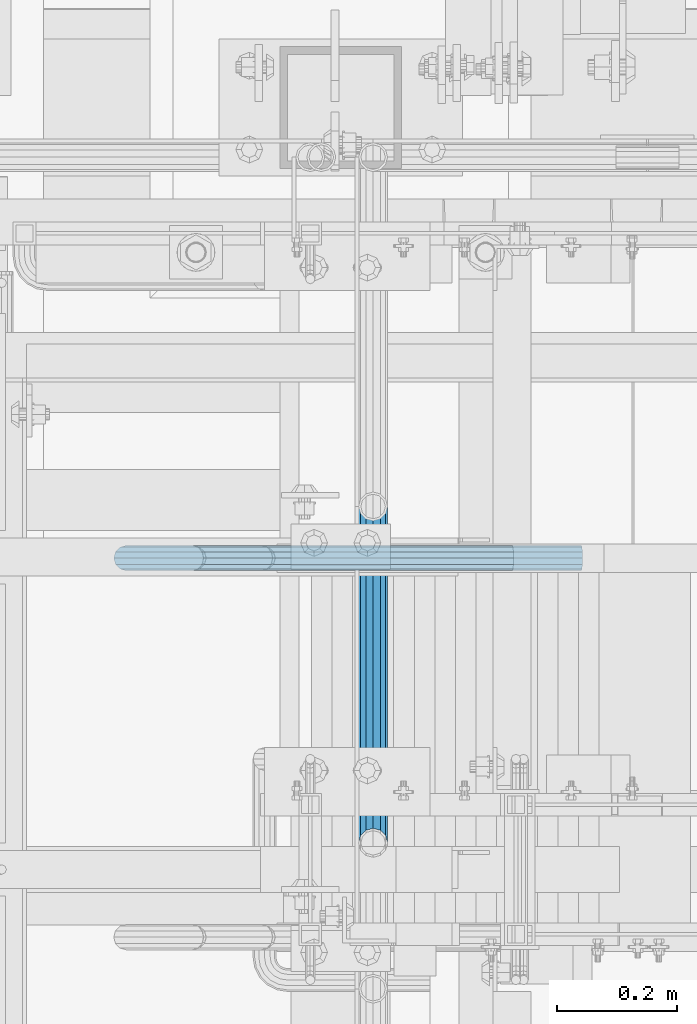
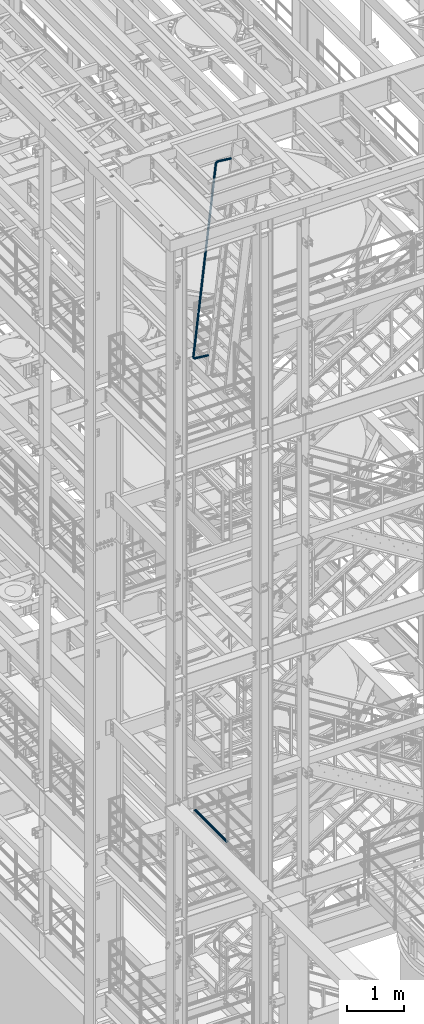
# One storey, part 964 of 1876: 2 beams, 2 elements without a shape of their own.
"""IFC2X3 building model written with IfcOpenShell, lengths in millimetres."""

from ifc_helpers import new_model, si_unit, frame, origin_with_axes, place, context, subcontext, project, spatial, faceted_brep, material, type_object, element, aggregate, save


model = new_model("IFC2X3")

# Units and contexts
model_context = context("Model", 3, precision=1e-05, world=origin_with_axes())
body_context = subcontext(model_context, "Body", "Model", "MODEL_VIEW")
ifc_project = project(units=[si_unit("LENGTHUNIT", "METRE", prefix="MILLI"), si_unit("AREAUNIT", "SQUARE_METRE"), si_unit("VOLUMEUNIT", "CUBIC_METRE"), si_unit("MASSUNIT", "GRAM", prefix="KILO"), si_unit("TIMEUNIT", "SECOND"), si_unit("PLANEANGLEUNIT", "RADIAN"), si_unit("SOLIDANGLEUNIT", "STERADIAN"), si_unit("THERMODYNAMICTEMPERATUREUNIT", "DEGREE_CELSIUS"), si_unit("LUMINOUSINTENSITYUNIT", "LUMEN")], contexts=[model_context])

# Site, building, storey
site_placement = place(None, origin_with_axes())
site = spatial("IfcSite", under=ifc_project, at=site_placement, CompositionType="ELEMENT")
building_placement = place(site_placement, origin_with_axes())
building = spatial("IfcBuilding", under=site, at=building_placement, Name="Undefined", CompositionType="ELEMENT")
storey_placement = place(building_placement, origin_with_axes())
storey = spatial("IfcBuildingStorey", under=building, at=storey_placement, Name="Undefined", CompositionType="ELEMENT", Elevation=0.0)

# Assembly, beam
assembly_1_placement = place(storey_placement, origin_with_axes())
assembly_1 = element("IfcElementAssembly", 1, at=assembly_1_placement, inside=storey, Name="RAIL", AssemblyPlace="NOTDEFINED", PredefinedType="RIGID_FRAME")
ifc_material = material()
beam_type_1 = type_object("IfcBeamType", Name="PIPE1-1/2SCH40", PredefinedType="NOTDEFINED")
beam_1_placement = place(assembly_1_placement, frame((1781.17499999995, -4654.55000114554, 8315.325), z_axis=(0.0, 0.0, 1.0), x_axis=(0.0, -1.0, 0.0)))
beam_1 = element("IfcBeam", 2, at=beam_1_placement, type_object=beam_type_1, material=ifc_material, Name="RAIL", ObjectType="PIPE1-1/2SCH40", context=body_context, shape_type="Brep", body=[
    faceted_brep([(1122.10280643392, -12.0650000000001, 20.8971929933177), (1122.10280643392, -12.0650000010112, 15.8661214301701), (1121.60937799578, -10.2235000000001, 17.7076214311801), (1118.86999942724, -2.11457518162206e-11, 20.4470000000001), (1118.86999942724, -2.11457518162206e-11, 24.1299999999992), (1121.60937799633, 10.2235000000001, 17.7076214311801), (1122.10280643392, 12.0649999989889, 15.866121432191), (1122.10280643392, 12.0650000000001, 20.8971929933177), (1142.99999942723, 24.1300000000001, 0.0), (1130.93499942724, 20.8971929933184, 12.0650000000005), (1130.93499942724, 20.8971929933184, -12.0650000000005), (1127.74542786611, 17.7076214311803, 10.2235000000001), (1130.48480643493, 20.4469999999999, 0.0), (1127.74542786611, 17.7076214311803, -10.2235000000001), (1122.10280643392, 12.0649999989889, -15.866121432191), (1122.10280643392, 12.0650000000001, -20.8971929933177), (1121.60937799633, 10.2235000000001, -17.7076214311801), (1118.86999942724, 0.0, -20.4470000000001), (1118.86999942724, 0.0, -24.1299999999992), (1122.10280643392, -12.0650000010112, -15.8661214301701), (1122.10280643392, -12.0650000000001, -20.8971929933177), (1121.60937799578, -10.2235000000001, -17.7076214311801), (1142.99999942724, -24.1300000010112, 0.0), (1130.93499942724, -20.8971929933184, -12.0650000000005), (1130.93499942724, -20.8971929933184, 12.0650000000005), (1127.74542786409, -17.7076214311803, -10.2235000000001), (1130.48480643291, -20.4469999999999, 0.0), (1127.74542786409, -17.7076214311803, 10.2235000000001), (12.0650000000064, -20.8971929933177, -12.0649999999987), (20.8971929933249, -12.0650000000005, -20.8971929933177), (0.0, 24.1299999999992, 0.0), (12.0650000000064, 20.8971929933177, -12.0649999999987), (12.0650000000064, 20.8971929933177, 12.0649999999987), (20.8971929933249, 12.0650000000005, 20.8971929933177), (24.1300000000064, 0.0, 24.130000000001), (20.8971929933249, 12.0650000000005, -20.8971929933177), (24.1300000000063, 0.0, -24.130000000001), (24.1300000000063, 0.0, -20.4470000000001), (20.8971929933249, -12.0650000000005, -15.8661214311796), (21.3906214311868, -10.2235000000001, -17.7076214311819), (21.3906214311868, 10.2235000000001, -17.7076214311819), (20.8971929933249, 12.0650000000005, -15.8661214311796), (15.2545715621445, 17.7076214311801, -10.2235000000001), (12.5151929933249, 20.4470000000001, 0.0), (15.2545715621445, 17.7076214311801, 10.2235000000001), (20.8971929933249, 12.0650000000005, 15.8661214311796), (21.3906214311868, 10.2235000000001, 17.7076214311819), (24.1300000000064, 0.0, 20.4470000000001), (21.3906214311868, -10.2235000000001, 17.7076214311819), (20.8971929933249, -12.0650000000005, 15.8661214311796), (20.8971929933249, -12.0650000000005, 20.8971929933177), (12.0650000000064, -20.8971929933177, 12.0649999999987), (0.0, -24.1299999999992, 0.0), (15.2545715621445, -17.7076214311801, 10.2235000000001), (12.5151929933249, -20.4470000000001, 0.0), (15.2545715621445, -17.7076214311801, -10.2235000000001)], [[[0, 1, 2, 3, 4]], [[4, 3, 5, 6, 7]], [[8, 9, 10]], [[7, 6, 11, 12, 13, 14, 15, 10, 9]], [[16, 17, 18, 15, 14]], [[19, 20, 18, 17, 21]], [[22, 23, 24]], [[24, 23, 20, 19, 25, 26, 27, 1, 0]], [[28, 29, 20, 23]], [[30, 31, 32]], [[33, 34, 4, 7]], [[32, 33, 7, 9]], [[30, 32, 9, 8]], [[31, 30, 8, 10]], [[35, 31, 10, 15]], [[36, 35, 15, 18]], [[29, 36, 18, 20]], [[37, 36, 29, 38, 39]], [[40, 41, 35, 36, 37]], [[32, 31, 35, 41, 42, 43, 44, 45, 33]], [[33, 45, 46, 47, 34]], [[34, 47, 48, 49, 50]], [[34, 50, 0, 4]], [[50, 51, 24, 0]], [[51, 52, 22, 24]], [[52, 28, 23, 22]], [[51, 28, 52]], [[50, 49, 53, 54, 55, 38, 29, 28, 51]], [[55, 54, 26, 25]], [[21, 39, 38, 55, 25, 19]], [[37, 39, 21, 17]], [[40, 37, 17, 16]], [[42, 41, 40, 16, 14, 13]], [[43, 42, 13, 12]], [[44, 43, 12, 11]], [[5, 46, 45, 44, 11, 6]], [[47, 46, 5, 3]], [[48, 47, 3, 2]], [[53, 49, 48, 2, 1, 27]], [[54, 53, 27, 26]]]),
])
aggregate(assembly_1, [beam_1])

assembly_2_placement = place(storey_placement, origin_with_axes())
assembly_2 = element("IfcElementAssembly", 3, at=assembly_2_placement, inside=storey, Name="RIGHT STRINGER", AssemblyPlace="NOTDEFINED", PredefinedType="RIGID_FRAME")
beam_type_2 = type_object("IfcBeamType", Name="PIPE1-1/4SCH40", PredefinedType="NOTDEFINED")
beam_2_placement = place(assembly_2_placement, frame((2128.15801915284, -5322.8875, 22426.9237260369), z_axis=(-0.113812491006334, 0.0, -0.993502248055299), x_axis=(-0.993502248055299, 0.0, 0.113812491006334)))
beam_2 = element("IfcBeam", 4, at=beam_2_placement, type_object=beam_type_2, material=ifc_material, Name="RAIL", ObjectType="PIPE1-1/4SCH40", context=body_context, shape_type="Brep", body=[
    faceted_brep([(9.09494701772928e-13, -21.0820000000003, 0.0), (0.0, -18.2575475625836, -10.5409999999993), (260.35000263722, -18.2575475625836, -10.5410004914556), (260.350002657111, -21.0820000000003, -4.91440005134791e-07), (0.0, -10.5410000000002, -18.2575475625836), (260.350002622659, -10.5410000000002, -18.2575480540509), (-4.28826751885936e-09, 0.0, -21.0820000000003), (260.350002617329, 0.0, -21.0820004914713), (0.0, 10.5410000000002, -18.2575475625836), (260.350002622659, 10.5410000000002, -18.2575480540509), (0.0, 18.2575475625836, -10.5409999999993), (260.35000263722, 18.2575475625836, -10.5410004914556), (9.09494701772928e-13, 21.0820000000003, 0.0), (260.350002657111, 21.0820000000003, -4.91440005134791e-07), (0.0, 18.2575475625836, 10.5409999999993), (260.350002677003, 18.2575475625836, 10.5409995085683), (0.0, 10.5410000000002, 18.2575475625836), (260.350002691564, 10.5410000000002, 18.2575470711672), (0.0, 0.0, 21.0820000000003), (260.350002696894, 0.0, 21.0819995085876), (0.0, -10.5410000000002, 18.2575475625836), (260.350002691564, -10.5410000000002, 18.2575470711672), (0.0, -18.2575475625836, 10.5409999999993), (260.350002677003, -18.2575475625836, 10.5409995085683), (0.0, -17.5259999999998, 0.0), (0.0, -15.1779612267264, 8.76300000000083), (260.350002673647, -15.1779612267264, 8.76299950856628), (260.350002657111, -17.5259999999998, -4.91440005134791e-07), (0.0, -8.76299999999992, 15.1779612267255), (260.350002685753, -8.76299999999992, 15.1779607353055), (0.0, 0.0, 17.5259999999998), (260.350002690184, 0.0, 17.5259995085835), (0.0, 8.76299999999992, 15.1779612267255), (260.350002685753, 8.76299999999992, 15.1779607353055), (0.0, 15.1779612267264, 8.76300000000083), (260.350002673647, 15.1779612267264, 8.76299950856628), (0.0, 17.5259999999998, 0.0), (260.350002657111, 17.5259999999998, -4.91440005134791e-07), (0.0, 15.1779612267264, -8.76300000000083), (260.350002640575, 15.1779612267264, -8.76300049145357), (0.0, 8.76299999999992, -15.1779612267255), (260.35000262847, 8.76299999999992, -15.1779617181928), (0.0, 0.0, -17.5259999999998), (260.350002624039, 0.0, -17.5260004914671), (0.0, -8.76299999999992, -15.1779612267255), (260.35000262847, -8.76299999999992, -15.1779617181928), (0.0, -15.1779612267264, -8.76300000000083), (260.350002640575, -15.1779612267264, -8.76300049145357), (274.08580829423, -21.0820000000003, 2.17553736977061), (270.828460176085, -18.2575475625836, 12.2006241144154), (268.443915855663, -10.5410000000002, 19.5394969617737), (267.57111205794, 0.0, 22.2257108590529), (268.443915855663, 10.5410000000002, 19.5394969617737), (270.828460176085, 18.2575475625836, 12.2006241144154), (274.08580829423, 21.0820000000003, 2.17553736977061), (277.343156412376, 18.2575475625836, -7.84954937486691), (279.727700732797, 10.5410000000002, -15.1884222222252), (280.600504530522, 0.0, -17.8746361195081), (279.727700732797, -10.5410000000002, -15.1884222222252), (277.343156412376, -18.2575475625836, -7.84954937486691), (279.501640105123, 0.0, -14.4926791454127), (278.776056225087, 8.76299999999992, -12.2595615681566), (276.793724199676, 15.1779612267264, -6.15857088781922), (274.08580829423, 17.5259999999998, 2.17553736977061), (271.377892388784, 15.1779612267264, 10.5096456273677), (269.395560363374, 8.76299999999992, 16.6106363077015), (268.669976483338, 0.0, 18.8437538849576), (269.395560363374, -8.76299999999992, 16.6106363077015), (271.377892388784, -15.1779612267264, 10.5096456273677), (274.08580829423, -17.5259999999998, 2.17553736977061), (276.793724199676, -15.1779612267264, -6.15857088781922), (278.776056225087, -8.76299999999992, -12.2595615681566), (292.672901908588, 18.2575475625836, -0.0386539485734829), (297.208574751905, 10.5410000000002, -6.28147207375514), (286.477057581359, 21.0820000000003, 8.4891942016402), (280.281213254131, 18.2575475625836, 17.0170423518503), (275.745540410813, 10.5410000000002, 23.2598604770355), (274.085368926903, 0.0, 25.544890502053), (275.745540410813, -10.5410000000002, 23.2598604770355), (280.281213254131, -18.2575475625836, 17.0170423518503), (286.477057581359, -21.0820000000003, 8.4891942016402), (292.672901908588, -18.2575475625836, -0.0386539485734829), (297.208574751905, -10.5410000000002, -6.28147207375514), (298.868746235816, 0.0, -8.56650209877625), (295.398439325548, -8.76299999999992, -3.79003438874497), (296.778581884461, 0.0, -5.68963766256275), (291.62781973291, -15.1779612267264, 1.39977826953327), (286.477057581359, -17.5259999999998, 8.4891942016402), (281.326295429808, -15.1779612267264, 15.5786101337435), (277.55567583717, -8.76299999999992, 20.768422792029), (276.175533278257, 0.0, 22.6680260658432), (277.55567583717, 8.76299999999992, 20.768422792029), (281.326295429808, 15.1779612267264, 15.5786101337435), (286.477057581359, 17.5259999999998, 8.4891942016402), (291.62781973291, 15.1779612267264, 1.39977826953327), (295.398439325548, 8.76299999999992, -3.79003438874497), (304.838656828675, 18.2575475625836, 12.1271009217089), (311.081474935276, 10.5410000000002, 7.5914280528159), (296.310808703854, 21.0820000000003, 18.322945283875), (287.782960579032, 18.2575475625836, 24.5187896460338), (281.540142472431, 10.5410000000002, 29.0544625149305), (279.25511245421, 0.0, 30.7146340081999), (281.540142472431, -10.5410000000002, 29.0544625149305), (287.782960579032, -18.2575475625836, 24.5187896460338), (296.310808703854, -21.0820000000003, 18.322945283875), (304.838656828675, -18.2575475625836, 12.1271009217089), (311.081474935276, -10.5410000000002, 7.5914280528159), (313.366504953497, 0.0, 5.93125655954645), (308.590037257687, -8.76299999999992, 9.40156348937671), (310.489640525846, 0.0, 8.02142092268332), (303.40022461485, -15.1779612267264, 13.172183103281), (296.310808703854, -17.5259999999998, 18.322945283875), (289.221392792858, -15.1779612267264, 23.4737074644654), (284.031580150021, -8.76299999999992, 27.2443270783624), (282.131976881861, 0.0, 28.6244696450594), (284.031580150021, 8.76299999999992, 27.2443270783624), (289.221392792858, 15.1779612267264, 23.4737074644654), (296.310808703854, 17.5259999999998, 18.322945283875), (303.40022461485, 15.1779612267264, 13.172183103281), (308.590037257687, 8.76299999999992, 9.40156348937671), (312.649552317749, 18.2575475625836, 27.4568463859578), (319.988425155334, 10.5410000000002, 25.0723020354744), (302.624465586464, 21.0820000000003, 30.7141945451658), (292.599378855178, 18.2575475625836, 33.9715427043739), (285.260506017593, 10.5410000000002, 36.3560870548536), (282.574292123894, 0.0, 37.2288908635783), (285.260506017593, -10.5410000000002, 36.3560870548536), (292.599378855178, -18.2575475625836, 33.9715427043739), (302.624465586464, -21.0820000000003, 30.7141945451658), (312.649552317749, -18.2575475625836, 27.4568463859578), (319.988425155334, -10.5410000000002, 25.0723020354744), (322.674639049034, 0.0, 24.1994982267497), (317.059564505163, -8.76299999999992, 26.0239465551822), (319.292682079444, 0.0, 25.2983626659989), (310.958573832954, -15.1779612267264, 28.0062786055823), (302.624465586464, -17.5259999999998, 30.7141945451658), (294.290357339974, -15.1779612267264, 33.4221104847456), (288.189366667764, -8.76299999999992, 35.4044425351494), (285.956249093484, 0.0, 36.1300264243291), (288.189366667764, 8.76299999999992, 35.4044425351494), (294.290357339974, 15.1779612267264, 33.4221104847456), (302.624465586464, 17.5259999999998, 30.7141945451658), (310.958573832954, 15.1779612267264, 28.0062786055823), (317.059564505163, 8.76299999999992, 26.0239465551822), (323.057551066515, -10.5410000000002, 44.4500001330634), (315.341003503932, -18.2575475625836, 44.4500001501037), (325.882003503932, 0.0, 44.4500001268316), (323.057551066515, 10.5410000000002, 44.4500001330634), (315.341003503932, 18.2575475625836, 44.4500001501037), (304.80000350393, 21.0820000000003, 44.4500001733868), (294.25900350393, 18.2575475625836, 44.4500001966699), (286.542455941346, 10.5410000000002, 44.4500002137138), (283.718003503929, 0.0, 44.4500002199493), (286.542455941346, -10.5410000000002, 44.4500002137138), (294.25900350393, -18.2575475625836, 44.4500001966699), (304.800003503935, -21.0820000000003, 44.4500001733904), (319.977964730658, -8.76299999999992, 44.4500001398665), (322.326003503932, 0.0, 44.4500001346823), (313.563003503931, -15.1779612267264, 44.4500001540328), (304.800003503935, -17.5259999999998, 44.4500001733904), (296.03700350393, -15.1779612267264, 44.4500001927445), (289.622042277204, -8.76299999999992, 44.4500002069108), (287.27400350393, 0.0, 44.4500002120949), (289.622042277204, 8.76299999999992, 44.4500002069108), (296.03700350393, 15.1779612267264, 44.4500001927445), (304.80000350393, 17.5259999999998, 44.4500001733868), (313.563003503931, 15.1779612267264, 44.4500001540328), (319.977964730658, 8.76299999999992, 44.4500001398665), (315.341012241819, -18.2575475625836, 4001.85807438963), (304.800012241817, -21.0820000000003, 4001.85807441292), (323.057559804403, -10.5410000000002, 4001.85807437259), (325.88201224182, 0.0, 4001.85807436635), (323.057559804403, 10.5410000000002, 4001.85807437259), (315.341012241819, 18.2575475625836, 4001.85807438963), (304.800012241817, 21.0820000000003, 4001.85807441292), (294.259012241816, 18.2575475625836, 4001.8580744362), (286.542464679232, 10.5410000000002, 4001.85807445324), (283.718012241815, 0.0, 4001.85807445948), (286.542464679232, -10.5410000000002, 4001.85807445324), (294.259012241816, -18.2575475625836, 4001.8580744362), (296.037012241816, -15.1779612267264, 4001.85807443227), (304.800012241817, -17.5259999999998, 4001.85807441292), (289.622051015089, -8.76299999999992, 4001.85807444644), (287.274012241815, 0.0, 4001.85807445162), (289.622051015089, 8.76299999999992, 4001.85807444644), (296.037012241817, 15.1779612267264, 4001.85807443227), (304.800012241817, 17.5259999999998, 4001.85807441292), (313.563012241819, 15.1779612267264, 4001.85807439356), (319.977973468545, 8.76299999999992, 4001.85807437939), (322.32601224182, 0.0, 4001.85807437421), (319.977973468545, -8.76299999999992, 4001.85807437939), (313.563012241819, -15.1779612267264, 4001.85807439356), (302.624471178057, -21.0820000000003, 4015.59388992073), (292.59938519289, -18.2575475625836, 4012.3365394652), (285.260512901501, -10.5410000000002, 4009.9519934337), (282.574299207724, 0.0, 4009.07918900968), (285.260512901501, 10.5410000000002, 4009.9519934337), (292.59938519289, 18.2575475625836, 4012.3365394652), (302.624471178057, 21.0820000000003, 4015.59388992073), (312.649557163223, 18.2575475625836, 4018.85124037625), (319.988429454612, 10.5410000000002, 4021.23578640775), (322.67464314839, 0.0, 4022.10859083178), (319.988429454612, -10.5410000000002, 4021.23578640775), (312.649557163223, -18.2575475625836, 4018.85124037625), (319.292686430502, 0.0, 4021.00972561786), (317.059569022422, 8.76299999999992, 4020.28414121717), (310.958578804279, 15.1779612267264, 4018.3018077693), (302.624471178057, 17.5259999999998, 4015.59388992073), (294.290363551834, 15.1779612267264, 4012.88597207216), (288.189373333692, 8.76299999999992, 4010.90363862429), (285.956255925611, 0.0, 4010.17805422359), (288.189373333692, -8.76299999999992, 4010.90363862429), (294.290363551834, -15.1779612267264, 4012.88597207216), (302.624471178057, -17.5259999999998, 4015.59388992073), (310.958578804279, -15.1779612267264, 4018.3018077693), (317.059569022422, -8.76299999999992, 4020.28414121717), (304.838650616203, 18.2575475625836, 4034.18099443829), (311.081466624913, 10.5410000000002, 4038.71667019467), (296.310805357153, 21.0820000000003, 4027.98514613173), (287.782960098103, 18.2575475625836, 4021.78929782518), (281.540144089393, 10.5410000000002, 4017.25362206879), (279.255114839053, 0.0, 4015.59344951863), (281.540144089393, -10.5410000000002, 4017.25362206879), (287.782960098103, -18.2575475625836, 4021.78929782518), (296.310805357153, -21.0820000000003, 4027.98514613173), (304.838650616203, -18.2575475625836, 4034.18099443829), (311.081466624913, -10.5410000000002, 4038.71667019467), (313.366495875254, 0.0, 4040.37684274484), (308.590029784569, -8.76299999999992, 4036.90653360574), (310.489632414369, 0.0, 4038.28667705106), (303.400218885761, -15.1779612267264, 4033.1359115914), (296.310805357153, -17.5259999999998, 4027.98514613173), (289.221391828546, -15.1779612267264, 4022.83438067207), (284.031580929738, -8.76299999999992, 4019.06375865772), (282.131978299937, 0.0, 4017.68361521241), (284.031580929738, 8.76299999999992, 4019.06375865772), (289.221391828546, 15.1779612267264, 4022.83438067207), (296.310805357153, 17.5259999999998, 4027.98514613173), (303.400218885761, 15.1779612267264, 4033.1359115914), (308.590029784569, 8.76299999999992, 4036.90653360574), (292.672879682134, 18.2575475625836, 4046.34675122807), (297.208548180417, 10.5410000000002, 4052.58957251011), (286.477041290332, 21.0820000000003, 4037.81889876553), (280.281202898531, 18.2575475625836, 4029.29104630299), (275.745534400247, 10.5410000000002, 4023.04822502095), (274.08536450673, 0.0, 4020.76319384044), (275.745534400247, -10.5410000000002, 4023.04822502095), (280.281202898531, -18.2575475625836, 4029.29104630299), (286.477041290332, -21.0820000000003, 4037.81889876553), (292.672879682134, -18.2575475625836, 4046.34675122807), (297.208548180418, -10.5410000000002, 4052.58957251011), (298.868718073934, 0.0, 4054.87460369062), (295.398414488114, -8.76299999999992, 4050.09813356524), (296.778555724893, 0.0, 4051.99773779964), (291.627798507612, -15.1779612267264, 4044.90831828259), (286.477041290332, -17.5259999999998, 4037.81889876553), (281.326284073052, -15.1779612267264, 4030.72947924848), (277.55566809255, -8.76299999999992, 4025.53966396582), (276.175526855771, 0.0, 4023.64005973142), (277.555668092551, 8.76299999999992, 4025.53966396582), (281.326284073052, 15.1779612267264, 4030.72947924848), (286.477041290332, 17.5259999999998, 4037.81889876553), (291.627798507612, 15.1779612267264, 4044.90831828259), (295.398414488114, 8.76299999999992, 4050.09813356524), (277.343116538931, 18.2575475625836, 4054.15763995225), (279.727654038023, 10.5410000000002, 4061.49651501599), (274.085777738892, 21.0820000000003, 4044.13255017997), (270.828438938854, 18.2575475625836, 4034.1074604077), (268.443901439761, 10.5410000000002, 4026.76858534397), (267.571100138817, 0.0, 4024.08237063544), (268.443901439761, -10.5410000000002, 4026.76858534397), (270.828438938854, -18.2575475625836, 4034.1074604077), (274.085777738892, -21.0820000000003, 4044.13255017997), (277.343116538931, -18.2575475625836, 4054.15763995225), (279.727654038023, -10.5410000000002, 4061.49651501599), (280.600455338968, 0.0, 4064.18272972452), (278.776012252628, -8.76299999999992, 4058.56765347738), (279.501594057028, 0.0, 4060.80077172905), (276.79368589796, -15.1779612267264, 4052.46666095451), (274.085777738892, -17.5259999999998, 4044.13255017997), (271.377869579826, -15.1779612267264, 4035.79843940544), (269.395543225157, -8.76299999999992, 4029.69744688257), (268.669961420757, 0.0, 4027.4643286309), (269.395543225157, 8.76299999999992, 4029.69744688257), (271.377869579826, 15.1779612267264, 4035.79843940544), (274.085777738892, 17.5259999999998, 4044.13255017997), (276.79368589796, 15.1779612267264, 4052.46666095451), (278.776012252628, 8.76299999999992, 4058.56765347738), (260.349938434631, -10.5410000000002, 4064.56562283665), (260.349947423173, -18.2575475625836, 4056.84907527406), (260.349935144596, 0.0, 4067.39007527407), (260.349938434631, 10.5410000000002, 4064.56562283665), (260.349947423173, 18.2575475625836, 4056.84907527406), (260.34995970175, 21.0820000000003, 4046.30807527405), (260.349971980326, 18.2575475625836, 4035.76707527404), (260.349980968868, 10.5410000000002, 4028.05052771145), (260.349984258902, 0.0, 4025.22607527403), (260.349980968868, -10.5410000000002, 4028.05052771145), (260.349971980326, -18.2575475625836, 4035.76707527404), (260.34995970175, -21.0820000000003, 4046.30807527406), (260.349942021855, -8.76299999999992, 4061.4860365008), (260.349939286766, 0.0, 4063.83407527407), (260.349949494259, -15.1779612267264, 4055.07107527406), (260.34995970175, -17.5259999999998, 4046.30807527406), (260.349969909241, -15.1779612267264, 4037.54507527404), (260.349977381643, -8.76299999999992, 4031.13011404731), (260.349980116732, 0.0, 4028.78207527403), (260.349977381643, 8.76299999999992, 4031.13011404731), (260.349969909241, 15.1779612267264, 4037.54507527404), (260.34995970175, 17.5259999999998, 4046.30807527405), (260.349949494259, 15.1779612267264, 4055.07107527406), (260.349942021855, 8.76299999999992, 4061.4860365008), (-2.4040230243827e-05, -18.2575475625836, 4056.84877200827), (-1.17616559123235e-05, -21.0820000000003, 4046.30777200826), (-3.30287707015486e-05, -10.5410000000002, 4064.56531957086), (-3.63188048027041e-05, 0.0, 4067.38977200828), (-3.30287707015486e-05, 10.5410000000002, 4064.56531957086), (-2.4040230243827e-05, 18.2575475625836, 4056.84877200827), (-1.17616559123235e-05, 21.0820000000003, 4046.30777200826), (5.16918873927352e-07, 18.2575475625836, 4035.76677200824), (9.50545887690168e-06, 10.5410000000002, 4028.05022444565), (1.27954934328045e-05, 0.0, 4025.22577200823), (9.50545887690168e-06, -10.5410000000002, 4028.05022444565), (5.16918873927352e-07, -18.2575475625836, 4035.76677200824), (-1.55416609004533e-06, -15.1779612267264, 4037.54477200824), (-1.17616559123235e-05, -17.5259999999998, 4046.30777200826), (5.91823487638976e-06, -8.76299999999992, 4031.12981078152), (8.65332350485915e-06, 0.0, 4028.78177200824), (5.91823487638976e-06, 8.76299999999992, 4031.12981078152), (-1.55416609004533e-06, 15.1779612267264, 4037.54477200824), (-1.17616559123235e-05, 17.5259999999998, 4046.30777200826), (-2.19691457346016e-05, 15.1779612267264, 4055.07077200826), (-2.94415462462894e-05, 8.76299999999992, 4061.485733235), (-3.21766348747587e-05, 0.0, 4063.83377200827), (-2.94415462462894e-05, -8.76299999999992, 4061.485733235), (-2.19691457346016e-05, -15.1779612267264, 4055.07077200826)], [[[0, 1, 2, 3]], [[1, 4, 5, 2]], [[4, 6, 7, 5]], [[6, 8, 9, 7]], [[8, 10, 11, 9]], [[10, 12, 13, 11]], [[12, 14, 15, 13]], [[14, 16, 17, 15]], [[16, 18, 19, 17]], [[18, 20, 21, 19]], [[20, 22, 23, 21]], [[22, 0, 3, 23]], [[24, 25, 26, 27]], [[25, 28, 29, 26]], [[28, 30, 31, 29]], [[30, 32, 33, 31]], [[32, 34, 35, 33]], [[34, 36, 37, 35]], [[36, 38, 39, 37]], [[38, 40, 41, 39]], [[40, 42, 43, 41]], [[42, 44, 45, 43]], [[44, 46, 47, 45]], [[46, 24, 27, 47]], [[22, 20, 18, 16, 14, 12, 10, 8, 6, 4, 1, 0], [46, 44, 42, 40, 38, 36, 34, 32, 30, 28, 25, 24]], [[23, 3, 48, 49]], [[21, 23, 49, 50]], [[19, 21, 50, 51]], [[17, 19, 51, 52]], [[15, 17, 52, 53]], [[13, 15, 53, 54]], [[11, 13, 54, 55]], [[9, 11, 55, 56]], [[7, 9, 56, 57]], [[5, 7, 57, 58]], [[2, 5, 58, 59]], [[3, 2, 59, 48]], [[41, 43, 60, 61]], [[39, 41, 61, 62]], [[37, 39, 62, 63]], [[35, 37, 63, 64]], [[33, 35, 64, 65]], [[31, 33, 65, 66]], [[29, 31, 66, 67]], [[26, 29, 67, 68]], [[27, 26, 68, 69]], [[47, 27, 69, 70]], [[45, 47, 70, 71]], [[43, 45, 71, 60]], [[55, 72, 73, 56]], [[54, 74, 72, 55]], [[53, 75, 74, 54]], [[52, 76, 75, 53]], [[51, 77, 76, 52]], [[50, 78, 77, 51]], [[49, 79, 78, 50]], [[48, 80, 79, 49]], [[59, 81, 80, 48]], [[58, 82, 81, 59]], [[57, 83, 82, 58]], [[56, 73, 83, 57]], [[71, 84, 85, 60]], [[70, 86, 84, 71]], [[69, 87, 86, 70]], [[68, 88, 87, 69]], [[67, 89, 88, 68]], [[66, 90, 89, 67]], [[65, 91, 90, 66]], [[64, 92, 91, 65]], [[63, 93, 92, 64]], [[62, 94, 93, 63]], [[61, 95, 94, 62]], [[60, 85, 95, 61]], [[72, 96, 97, 73]], [[74, 98, 96, 72]], [[75, 99, 98, 74]], [[76, 100, 99, 75]], [[77, 101, 100, 76]], [[78, 102, 101, 77]], [[79, 103, 102, 78]], [[80, 104, 103, 79]], [[81, 105, 104, 80]], [[82, 106, 105, 81]], [[83, 107, 106, 82]], [[73, 97, 107, 83]], [[84, 108, 109, 85]], [[86, 110, 108, 84]], [[87, 111, 110, 86]], [[88, 112, 111, 87]], [[89, 113, 112, 88]], [[90, 114, 113, 89]], [[91, 115, 114, 90]], [[92, 116, 115, 91]], [[93, 117, 116, 92]], [[94, 118, 117, 93]], [[95, 119, 118, 94]], [[85, 109, 119, 95]], [[96, 120, 121, 97]], [[98, 122, 120, 96]], [[99, 123, 122, 98]], [[100, 124, 123, 99]], [[101, 125, 124, 100]], [[102, 126, 125, 101]], [[103, 127, 126, 102]], [[104, 128, 127, 103]], [[105, 129, 128, 104]], [[106, 130, 129, 105]], [[107, 131, 130, 106]], [[97, 121, 131, 107]], [[108, 132, 133, 109]], [[110, 134, 132, 108]], [[111, 135, 134, 110]], [[112, 136, 135, 111]], [[113, 137, 136, 112]], [[114, 138, 137, 113]], [[115, 139, 138, 114]], [[116, 140, 139, 115]], [[117, 141, 140, 116]], [[118, 142, 141, 117]], [[119, 143, 142, 118]], [[109, 133, 143, 119]], [[130, 144, 145, 129]], [[131, 146, 144, 130]], [[121, 147, 146, 131]], [[120, 148, 147, 121]], [[122, 149, 148, 120]], [[123, 150, 149, 122]], [[124, 151, 150, 123]], [[125, 152, 151, 124]], [[126, 153, 152, 125]], [[127, 154, 153, 126]], [[128, 155, 154, 127]], [[129, 145, 155, 128]], [[132, 156, 157, 133]], [[134, 158, 156, 132]], [[135, 159, 158, 134]], [[136, 160, 159, 135]], [[137, 161, 160, 136]], [[138, 162, 161, 137]], [[139, 163, 162, 138]], [[140, 164, 163, 139]], [[141, 165, 164, 140]], [[142, 166, 165, 141]], [[143, 167, 166, 142]], [[133, 157, 167, 143]], [[155, 145, 168, 169]], [[145, 144, 170, 168]], [[144, 146, 171, 170]], [[146, 147, 172, 171]], [[147, 148, 173, 172]], [[148, 149, 174, 173]], [[149, 150, 175, 174]], [[150, 151, 176, 175]], [[151, 152, 177, 176]], [[152, 153, 178, 177]], [[153, 154, 179, 178]], [[154, 155, 169, 179]], [[159, 160, 180, 181]], [[160, 161, 182, 180]], [[161, 162, 183, 182]], [[162, 163, 184, 183]], [[163, 164, 185, 184]], [[164, 165, 186, 185]], [[165, 166, 187, 186]], [[166, 167, 188, 187]], [[167, 157, 189, 188]], [[157, 156, 190, 189]], [[156, 158, 191, 190]], [[158, 159, 181, 191]], [[179, 169, 192, 193]], [[178, 179, 193, 194]], [[177, 178, 194, 195]], [[176, 177, 195, 196]], [[175, 176, 196, 197]], [[174, 175, 197, 198]], [[173, 174, 198, 199]], [[172, 173, 199, 200]], [[171, 172, 200, 201]], [[170, 171, 201, 202]], [[168, 170, 202, 203]], [[169, 168, 203, 192]], [[188, 189, 204, 205]], [[187, 188, 205, 206]], [[186, 187, 206, 207]], [[185, 186, 207, 208]], [[184, 185, 208, 209]], [[183, 184, 209, 210]], [[182, 183, 210, 211]], [[180, 182, 211, 212]], [[181, 180, 212, 213]], [[191, 181, 213, 214]], [[190, 191, 214, 215]], [[189, 190, 215, 204]], [[199, 216, 217, 200]], [[198, 218, 216, 199]], [[197, 219, 218, 198]], [[196, 220, 219, 197]], [[195, 221, 220, 196]], [[194, 222, 221, 195]], [[193, 223, 222, 194]], [[192, 224, 223, 193]], [[203, 225, 224, 192]], [[202, 226, 225, 203]], [[201, 227, 226, 202]], [[200, 217, 227, 201]], [[215, 228, 229, 204]], [[214, 230, 228, 215]], [[213, 231, 230, 214]], [[212, 232, 231, 213]], [[211, 233, 232, 212]], [[210, 234, 233, 211]], [[209, 235, 234, 210]], [[208, 236, 235, 209]], [[207, 237, 236, 208]], [[206, 238, 237, 207]], [[205, 239, 238, 206]], [[204, 229, 239, 205]], [[216, 240, 241, 217]], [[218, 242, 240, 216]], [[219, 243, 242, 218]], [[220, 244, 243, 219]], [[221, 245, 244, 220]], [[222, 246, 245, 221]], [[223, 247, 246, 222]], [[224, 248, 247, 223]], [[225, 249, 248, 224]], [[226, 250, 249, 225]], [[227, 251, 250, 226]], [[217, 241, 251, 227]], [[228, 252, 253, 229]], [[230, 254, 252, 228]], [[231, 255, 254, 230]], [[232, 256, 255, 231]], [[233, 257, 256, 232]], [[234, 258, 257, 233]], [[235, 259, 258, 234]], [[236, 260, 259, 235]], [[237, 261, 260, 236]], [[238, 262, 261, 237]], [[239, 263, 262, 238]], [[229, 253, 263, 239]], [[240, 264, 265, 241]], [[242, 266, 264, 240]], [[243, 267, 266, 242]], [[244, 268, 267, 243]], [[245, 269, 268, 244]], [[246, 270, 269, 245]], [[247, 271, 270, 246]], [[248, 272, 271, 247]], [[249, 273, 272, 248]], [[250, 274, 273, 249]], [[251, 275, 274, 250]], [[241, 265, 275, 251]], [[252, 276, 277, 253]], [[254, 278, 276, 252]], [[255, 279, 278, 254]], [[256, 280, 279, 255]], [[257, 281, 280, 256]], [[258, 282, 281, 257]], [[259, 283, 282, 258]], [[260, 284, 283, 259]], [[261, 285, 284, 260]], [[262, 286, 285, 261]], [[263, 287, 286, 262]], [[253, 277, 287, 263]], [[274, 288, 289, 273]], [[275, 290, 288, 274]], [[265, 291, 290, 275]], [[264, 292, 291, 265]], [[266, 293, 292, 264]], [[267, 294, 293, 266]], [[268, 295, 294, 267]], [[269, 296, 295, 268]], [[270, 297, 296, 269]], [[271, 298, 297, 270]], [[272, 299, 298, 271]], [[273, 289, 299, 272]], [[276, 300, 301, 277]], [[278, 302, 300, 276]], [[279, 303, 302, 278]], [[280, 304, 303, 279]], [[281, 305, 304, 280]], [[282, 306, 305, 281]], [[283, 307, 306, 282]], [[284, 308, 307, 283]], [[285, 309, 308, 284]], [[286, 310, 309, 285]], [[287, 311, 310, 286]], [[277, 301, 311, 287]], [[299, 289, 312, 313]], [[289, 288, 314, 312]], [[288, 290, 315, 314]], [[290, 291, 316, 315]], [[291, 292, 317, 316]], [[292, 293, 318, 317]], [[293, 294, 319, 318]], [[294, 295, 320, 319]], [[295, 296, 321, 320]], [[296, 297, 322, 321]], [[297, 298, 323, 322]], [[298, 299, 313, 323]], [[303, 304, 324, 325]], [[304, 305, 326, 324]], [[305, 306, 327, 326]], [[306, 307, 328, 327]], [[307, 308, 329, 328]], [[308, 309, 330, 329]], [[309, 310, 331, 330]], [[310, 311, 332, 331]], [[311, 301, 333, 332]], [[301, 300, 334, 333]], [[300, 302, 335, 334]], [[302, 303, 325, 335]], [[314, 315, 316, 317, 318, 319, 320, 321, 322, 323, 313, 312], [326, 327, 328, 329, 330, 331, 332, 333, 334, 335, 325, 324]]]),
])
aggregate(assembly_2, [beam_2])

save(model, "model.ifc")
